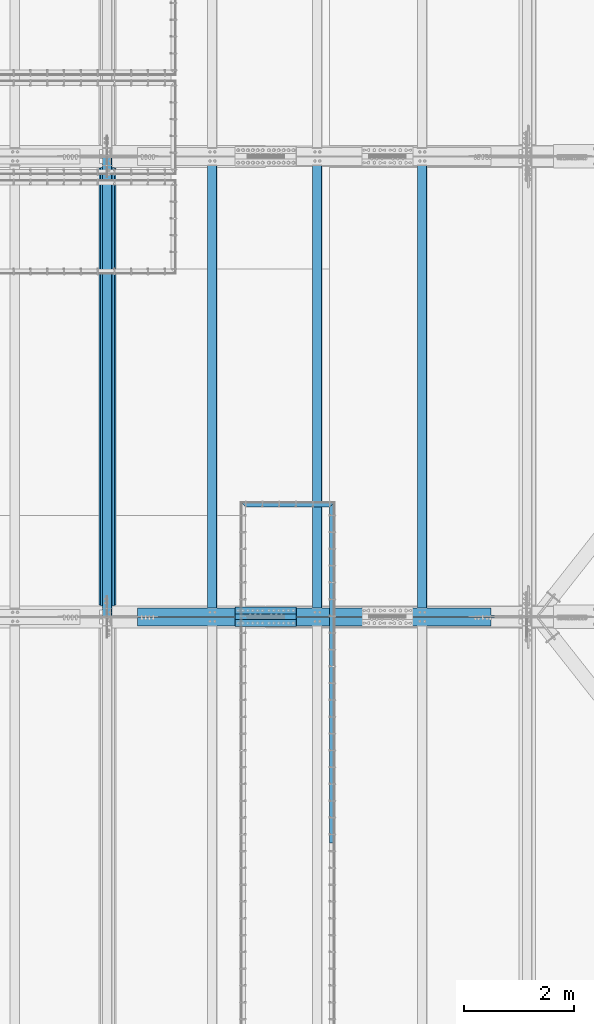
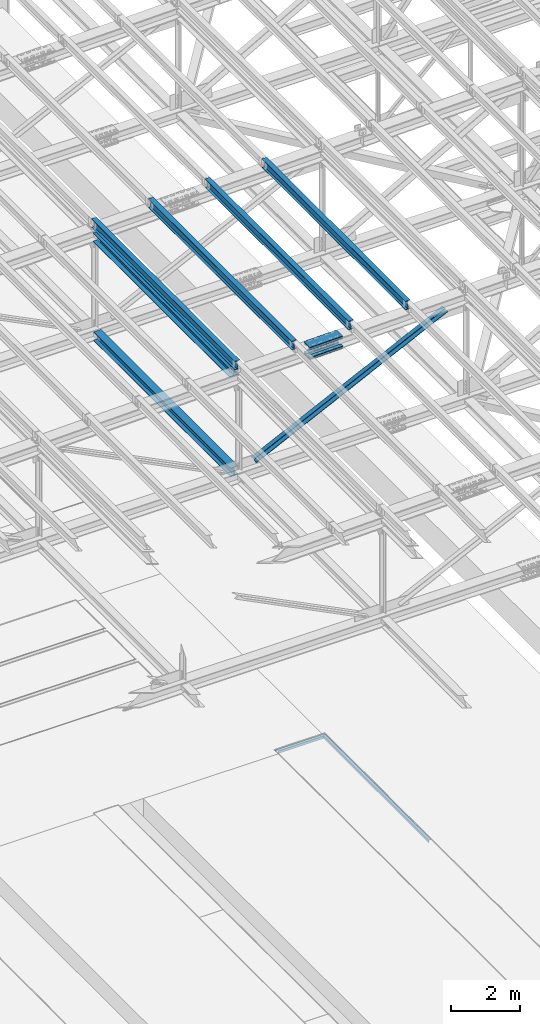
# One storey, part 1853 of 3843: 14 beams, 2 members, 11 elements without a shape of their own.
"""IFC2X3 building model written with IfcOpenShell, lengths in millimetres."""

from ifc_helpers import new_model, si_unit, frame, origin_with_axes, place, context, subcontext, project, spatial, faceted_brep, material, type_object, element, aggregate, save


model = new_model("IFC2X3")

# Units and contexts
model_context = context("Model", 3, precision=1e-05, world=origin_with_axes())
body_context = subcontext(model_context, "Body", "Model", "MODEL_VIEW")
ifc_project = project(units=[si_unit("LENGTHUNIT", "METRE", prefix="MILLI"), si_unit("AREAUNIT", "SQUARE_METRE"), si_unit("VOLUMEUNIT", "CUBIC_METRE"), si_unit("MASSUNIT", "GRAM", prefix="KILO"), si_unit("TIMEUNIT", "SECOND"), si_unit("PLANEANGLEUNIT", "RADIAN"), si_unit("SOLIDANGLEUNIT", "STERADIAN"), si_unit("THERMODYNAMICTEMPERATUREUNIT", "DEGREE_CELSIUS"), si_unit("LUMINOUSINTENSITYUNIT", "LUMEN")], contexts=[model_context])

# Site, building, storey
site_placement = place(None, origin_with_axes())
site = spatial("IfcSite", under=ifc_project, at=site_placement, CompositionType="ELEMENT")
building_placement = place(site_placement, origin_with_axes())
building = spatial("IfcBuilding", under=site, at=building_placement, Name="Undefined", CompositionType="ELEMENT")
storey_placement = place(building_placement, origin_with_axes())
storey = spatial("IfcBuildingStorey", under=building, at=storey_placement, Name="Undefined", CompositionType="ELEMENT", Elevation=0.0)

# Assembly, beam
assembly_1_placement = place(storey_placement, origin_with_axes())
assembly_1 = element("IfcElementAssembly", 1, at=assembly_1_placement, inside=storey, Name="EMBED_ANGLE", AssemblyPlace="NOTDEFINED", PredefinedType="RIGID_FRAME")
ifc_material_1 = material(Name="STEEL/A36")
beam_type_1 = type_object("IfcBeamType", Name="L3-1/2X3-1/2X5/16", PredefinedType="NOTDEFINED")
beam_1_placement = place(assembly_1_placement, frame((65056.5755709549, 52597.0501953125, 30410.15), z_axis=(0.0, 0.0, -1.0), x_axis=(1.0, 0.0, 0.0)))
beam_1 = element("IfcBeam", 2, at=beam_1_placement, type_object=beam_type_1, material=ifc_material_1, Name="EMBED_ANGLE", ObjectType="L3-1/2X3-1/2X5/16", context=body_context, shape_type="Brep", body=[
    faceted_brep([(88.8999999971129, 44.4500000000007, -44.4499999999971), (88.8999999965163, 44.4499999999971, 44.4500000000007), (1612.83647438452, 44.4499999999971, 44.4500000000007), (1612.83647438452, 44.4499999999971, -44.4500000000007), (80.9624999965163, 36.5124999999971, 44.4500000000007), (1620.7739717074, 36.5124999999971, 44.4500000000007), (80.9624999971129, 36.5125000000007, -36.5124999999971), (1620.77392277028, 36.5125000000007, -36.5125000083208), (3.63797880709171e-12, -44.4499999999971, -36.5125000000007), (1701.73644440077, -44.4500000000044, -36.5125000000007), (3.63797880709171e-12, -44.4499999999971, -44.4500000000007), (1701.73644440077, -44.4500000000044, -44.4500000000007)], [[[0, 1, 2, 3]], [[1, 4, 5, 2]], [[4, 6, 7, 5]], [[6, 8, 9, 7]], [[8, 10, 11, 9]], [[10, 0, 3, 11]], [[5, 7, 9, 11, 3, 2]], [[10, 8, 6, 4, 1, 0]]]),
])
aggregate(assembly_1, [beam_1])

assembly_2_placement = place(storey_placement, origin_with_axes())
assembly_2 = element("IfcElementAssembly", 3, at=assembly_2_placement, inside=storey, Name="EMBED_ANGLE", AssemblyPlace="NOTDEFINED", PredefinedType="RIGID_FRAME")
beam_2_placement = place(assembly_2_placement, frame((66713.8620305814, 52641.4996249862, 30410.15), z_axis=(0.0, 0.0, -1.0), x_axis=(0.0, -1.0, 0.0)))
beam_2 = element("IfcBeam", 4, at=beam_2_placement, type_object=beam_type_1, material=ifc_material_1, Name="EMBED_ANGLE", ObjectType="L3-1/2X3-1/2X5/16", context=body_context, shape_type="Brep", body=[
    faceted_brep([(88.8999999971129, 44.4500000000007, -44.4499999999971), (88.8999999965163, 44.4499999999971, 44.4500000000007), (6184.89942989353, 44.4500000362459, 44.4500000000007), (6184.89942989353, 44.4500000362459, -44.4500000000007), (80.9624999965163, 36.5124999999971, 44.4500000000007), (6184.89942989351, 36.5125000362459, 44.4500000000007), (80.9624999971129, 36.5125000000007, -36.5124999999971), (6184.89942989351, 36.5125000362459, -36.5125000000007), (3.63797880709171e-12, -44.4499999999971, -36.5125000000007), (6184.8994298934, -44.4499999637628, -36.5125000000007), (3.63797880709171e-12, -44.4499999999971, -44.4500000000007), (6184.8994298934, -44.4499999637628, -44.4500000000007)], [[[0, 1, 2, 3]], [[1, 4, 5, 2]], [[4, 6, 7, 5]], [[6, 8, 9, 7]], [[8, 10, 11, 9]], [[10, 0, 3, 11]], [[5, 7, 9, 11, 3, 2]], [[10, 8, 6, 4, 1, 0]]]),
])
aggregate(assembly_2, [beam_2])

assembly_3_placement = place(storey_placement, origin_with_axes())
assembly_3 = element("IfcElementAssembly", 5, at=assembly_3_placement, inside=storey, Name="BEAM", AssemblyPlace="NOTDEFINED", PredefinedType="RIGID_FRAME")
ifc_material_2 = material(Name="STEEL/A992")
beam_type_2 = type_object("IfcBeamType", Name="W12X26", PredefinedType="NOTDEFINED")
beam_3_placement = place(assembly_3_placement, frame((62633.1092623187, 50558.6422025775, 46219.7893078757), z_axis=(-0.0211520984675226, -0.000371508000112954, 0.999776200312963), x_axis=(0.0, 0.99999993095969, 0.000371591999985175)))
beam_3 = element("IfcBeam", 6, at=beam_3_placement, type_object=beam_type_2, material=ifc_material_2, Name="BEAM", ObjectType="W12X26", context=body_context, shape_type="Brep", body=[
    faceted_brep([(12.6993519677417, 82.5499999996464, -155.575000000448), (12.7028905899642, 82.5499999996537, -146.050000000418), (8343.90346575781, 82.5499999991371, -146.049999975963), (8343.89992713558, 82.5499999991225, -155.574999975994), (12.703514473782, 3.17499999978463, -146.050000000469), (8343.90408964162, 3.17499999926804, -146.049999976014), (12.8120322219984, 3.17500000020664, 146.050000000563), (8344.01260738984, 3.17499999969004, 146.05000002501), (12.8114083381806, 82.5500000000684, 146.050000000607), (8344.01198350602, 82.5499999995518, 146.050000025069), (12.8149469604105, 82.5500000000829, 155.575000000645), (8344.01552212825, 82.5499999995664, 155.575000025099), (12.8162446387505, -82.5499999996464, 155.575000000543), (8344.01681980658, -82.550000000163, 155.575000024997), (12.812706016528, -82.5499999996609, 146.050000000512), (8344.01328118436, -82.5500000001775, 146.050000024967), (12.8120821327102, -3.17499999979191, 146.050000000549), (8344.01265730055, -3.1750000003085, 146.05000002501), (12.7035643844938, -3.17500000020664, -146.050000000469), (8343.90413955232, -3.17500000072323, -146.049999976014), (12.7041882683043, -82.5500000000684, -146.05000000052), (8343.90476343614, -82.550000000585, -146.049999976058), (12.7006496460817, -82.5500000000829, -155.57500000055), (8343.90122481393, -82.5500000005995, -155.574999976096)], [[[0, 1, 2, 3]], [[1, 4, 5, 2]], [[4, 6, 7, 5]], [[6, 8, 9, 7]], [[8, 10, 11, 9]], [[10, 12, 13, 11]], [[12, 14, 15, 13]], [[14, 16, 17, 15]], [[16, 18, 19, 17]], [[18, 20, 21, 19]], [[20, 22, 23, 21]], [[22, 0, 3, 23]], [[5, 7, 9, 11, 13, 15, 17, 19, 21, 23, 3, 2]], [[22, 20, 18, 16, 14, 12, 10, 8, 6, 4, 1, 0]]]),
])
aggregate(assembly_3, [beam_3])

assembly_4_placement = place(storey_placement, origin_with_axes())
assembly_4 = element("IfcElementAssembly", 7, at=assembly_4_placement, inside=storey, Name="BEAM", AssemblyPlace="NOTDEFINED", PredefinedType="RIGID_FRAME")
beam_4_placement = place(assembly_4_placement, frame((68348.1092623159, 50558.6295614975, 46344.0380601221), z_axis=(-0.0211520981762442, -0.000452761999920767, 0.999776166824012), x_axis=(0.0, 0.999999897457093, 0.000452864000207387)))
beam_4 = element("IfcBeam", 8, at=beam_4_placement, type_object=beam_type_2, material=ifc_material_2, Name="BEAM", ObjectType="W12X26", context=body_context, shape_type="Brep", body=[
    faceted_brep([(12.6991634509395, 82.5499999998428, -155.574999999844), (12.7035230675392, 82.5500000008324, -146.049999999836), (8343.90437742035, 82.5500000011525, -146.050000015217), (8343.9000648554, 82.5500000011816, -155.575000015211), (12.7042834026215, 3.17500000041036, -146.049999999988), (8343.90513775544, 3.17500000073051, -146.05000001537), (12.8365353946574, 3.17499999965366, 146.049999999952), (8344.03738974747, 3.17499999997381, 146.049999984571), (12.8357750595824, 82.5500000000757, 146.050000000105), (8344.0366294124, 82.5500000003958, 146.049999984723), (12.8400876245432, 82.5500000000611, 155.575000000114), (8344.04094197735, 82.5500000003813, 155.574999984725), (12.8416691215025, -82.5500000008469, 155.574999999786), (8344.04252347432, -82.5500000005268, 155.574999984397), (12.8373565565416, -82.5500000008033, 146.049999999785), (8344.03821090936, -82.5500000004831, 146.049999984403), (12.8365962214666, -3.17500000036671, 146.049999999945), (8344.03745057428, -3.17500000004657, 146.049999984563), (12.7043442294234, -3.17499999962456, -146.049999999996), (8343.90519858224, -3.17499999930442, -146.050000015377), (12.7051045645057, -82.5500000000466, -146.050000000156), (8343.90595891731, -82.5499999997264, -146.050000015537), (12.700839471705, -82.5500000010798, -155.574999999444), (8343.90164635235, -82.5499999997119, -155.575000015531)], [[[0, 1, 2, 3]], [[1, 4, 5, 2]], [[4, 6, 7, 5]], [[6, 8, 9, 7]], [[8, 10, 11, 9]], [[10, 12, 13, 11]], [[12, 14, 15, 13]], [[14, 16, 17, 15]], [[16, 18, 19, 17]], [[18, 20, 21, 19]], [[20, 22, 23, 21]], [[22, 0, 3, 23]], [[5, 7, 9, 11, 13, 15, 17, 19, 21, 23, 3, 2]], [[22, 20, 18, 16, 14, 12, 10, 8, 6, 4, 1, 0]]]),
])
aggregate(assembly_4, [beam_4])

assembly_5_placement = place(storey_placement, origin_with_axes())
assembly_5 = element("IfcElementAssembly", 9, at=assembly_5_placement, inside=storey, Name="BEAM", AssemblyPlace="NOTDEFINED", PredefinedType="RIGID_FRAME")
beam_5_placement = place(assembly_5_placement, frame((66443.1092623624, 50558.6337716893, 46303.2830395796), z_axis=(-0.0211520979246561, -0.000425699999883364, 0.999776178718465), x_axis=(0.0, 0.999999909349305, 0.000425795000149042)))
beam_5 = element("IfcBeam", 10, at=beam_5_placement, type_object=beam_type_2, material=ifc_material_2, Name="BEAM", ObjectType="W12X26", context=body_context, shape_type="Brep", body=[
    faceted_brep([(12.6992577420606, 82.5500000004831, -155.575000000186), (12.7033125324306, 82.5500000004686, -146.050000000192), (8343.90406775389, 82.5500000007451, -146.050000013172), (8343.90001296352, 82.5500000007596, -155.575000013159), (12.7040274201136, 3.17500000004657, -146.049999999908), (8343.90478264158, 3.17500000032305, -146.050000012889), (12.8283743247084, 3.17499999998836, 146.049999999836), (8344.02912954616, 3.17500000025029, 146.049999986863), (12.8276594370109, 82.5500000004104, 146.049999999566), (8344.02841465847, 82.5500000006869, 146.049999986586), (12.8317142273809, 82.5500000004249, 155.574999999546), (8344.03246944884, 82.5500000006869, 155.574999986587), (12.8332011937746, -82.5500000004977, 155.575000000128), (8344.03395641524, -82.5500000002212, 155.574999987155), (12.8291464034119, -82.5500000004831, 146.050000000141), (8344.02990162488, -82.5500000002066, 146.049999987161), (12.8284315157143, -3.17500000004657, 146.049999999857), (8344.02918673718, -3.17499999977008, 146.049999986884), (12.704084611134, -3.17499999998836, -146.049999999886), (8343.90483983259, -3.17499999972642, -146.050000012867), (12.7047994988243, -82.5500000004104, -146.049999999617), (8343.90555472028, -82.5500000001339, -146.050000012583), (12.7007447084616, -82.5500000004249, -155.574999999604), (8343.90149992992, -82.5500000001484, -155.575000012577)], [[[0, 1, 2, 3]], [[1, 4, 5, 2]], [[4, 6, 7, 5]], [[6, 8, 9, 7]], [[8, 10, 11, 9]], [[10, 12, 13, 11]], [[12, 14, 15, 13]], [[14, 16, 17, 15]], [[16, 18, 19, 17]], [[18, 20, 21, 19]], [[20, 22, 23, 21]], [[22, 0, 3, 23]], [[5, 7, 9, 11, 13, 15, 17, 19, 21, 23, 3, 2]], [[22, 20, 18, 16, 14, 12, 10, 8, 6, 4, 1, 0]]]),
])
aggregate(assembly_5, [beam_5])

assembly_6_placement = place(storey_placement, origin_with_axes())
assembly_6 = element("IfcElementAssembly", 11, at=assembly_6_placement, inside=storey, Name="BEAM", AssemblyPlace="NOTDEFINED", PredefinedType="RIGID_FRAME")
beam_6_placement = place(assembly_6_placement, frame((64538.1092623442, 50558.637985359, 46261.8962503558), z_axis=(-0.021152097688544, -0.000398615999954926, 0.999776189888847), x_axis=(0.0, 0.999999920517158, 0.000398704999807439)))
beam_6 = element("IfcBeam", 12, at=beam_6_placement, type_object=beam_type_2, material=ifc_material_2, Name="BEAM", ObjectType="W12X26", context=body_context, shape_type="Brep", body=[
    faceted_brep([(12.6993519677417, 82.5499999996464, -155.575000000448), (12.7031016321926, 82.5499999993262, -146.05000000009), (8343.90376382439, 82.5499999992171, -146.049999995099), (8343.89992713558, 82.5499999991225, -155.574999975994), (12.7037710372169, 3.17499999947904, -146.050000000352), (8343.90443322941, 3.1749999993699, -146.049999995354), (12.8202067210586, 3.17500000050495, 146.050000000396), (8344.02086891326, 3.17500000038854, 146.050000005387), (12.8195373160343, 82.5500000003449, 146.05000000065), (8344.02019950824, 82.5500000002285, 146.050000005642), (12.8233341318119, 82.550000000374, 155.575000000674), (8344.02399632402, 82.5500000002648, 155.575000005665), (12.8247264942547, -82.5499999993117, 155.575000000143), (8344.02538868646, -82.5499999994136, 155.575000005134), (12.8209296784771, -82.5499999993408, 146.050000000112), (8344.02159187067, -82.5499999994427, 146.050000005103), (12.82026027346, -3.17499999949359, 146.050000000374), (8344.02092246566, -3.17499999960273, 146.050000005373), (12.7038245896183, -3.17500000050495, -146.050000000374), (8343.90448678181, -3.17500000062137, -146.049999995383), (12.7044939946281, -82.5500000003594, -146.050000000629), (8343.90515618683, -82.5500000004613, -146.049999995637), (12.7006496460817, -82.5500000000829, -155.57500000055), (8343.90135937105, -82.5500000004904, -155.574999995653)], [[[0, 1, 2, 3]], [[1, 4, 5, 2]], [[4, 6, 7, 5]], [[6, 8, 9, 7]], [[8, 10, 11, 9]], [[10, 12, 13, 11]], [[12, 14, 15, 13]], [[14, 16, 17, 15]], [[16, 18, 19, 17]], [[18, 20, 21, 19]], [[20, 22, 23, 21]], [[22, 0, 3, 23]], [[5, 7, 9, 11, 13, 15, 17, 19, 21, 23, 3, 2]], [[22, 20, 18, 16, 14, 12, 10, 8, 6, 4, 1, 0]]]),
])
aggregate(assembly_6, [beam_6])

# Assembly, beams
assembly_7_placement = place(storey_placement, origin_with_axes())
assembly_7 = element("IfcElementAssembly", 13, at=assembly_7_placement, inside=storey, Name="BEAM", AssemblyPlace="NOTDEFINED", PredefinedType="RIGID_FRAME")
ifc_material_3 = material(Name="STEEL/A572-50")
beam_type_3 = type_object("IfcBeamType", PredefinedType="NOTDEFINED")
beam_7_placement = place(assembly_7_placement, frame((64955.3532574287, 50673.0, 46066.1585524104), z_axis=(0.0, -1.0, 0.0), x_axis=(0.999763484909041, 0.0, 0.0217479709980223)))
beam_7 = element("IfcBeam", 14, at=beam_7_placement, type_object=beam_type_3, material=ifc_material_3, Name="PLATE", context=body_context, shape_type="Brep", body=[
    faceted_brep([(-4.36557456851006e-11, 12.7000000000116, -63.5), (-4.36557456851006e-11, 12.7000000000116, 63.5), (1104.90000001677, 12.7000000017251, 63.5), (1104.90000001677, 12.7000000017251, -63.5), (1.45519152283669e-11, -12.700000000008, 63.5), (1104.90000001682, -12.6999999982909, 63.5), (1.45519152283669e-11, -12.700000000008, -63.5), (1104.90000001682, -12.6999999982909, -63.5)], [[[0, 1, 2, 3]], [[1, 4, 5, 2]], [[4, 6, 7, 5]], [[6, 0, 3, 7]], [[5, 7, 3, 2]], [[6, 4, 1, 0]]]),
])
beam_8_placement = place(assembly_7_placement, frame((64961.7741729287, 50673.0, 45770.9863303139), z_axis=(0.0, -1.0, 0.0), x_axis=(0.999763484909041, 0.0, 0.0217479709980223)))
beam_8 = element("IfcBeam", 15, at=beam_8_placement, type_object=beam_type_3, material=ifc_material_3, Name="PLATE", context=body_context, shape_type="Brep", body=[
    faceted_brep([(-4.36557456851006e-11, 12.7000000000116, -63.5), (-4.36557456851006e-11, 12.7000000000116, 63.5), (1104.90000001677, 12.7000000017251, 63.5), (1104.90000001677, 12.7000000017251, -63.5), (1.45519152283669e-11, -12.700000000008, 63.5), (1104.90000001682, -12.6999999982909, 63.5), (1.45519152283669e-11, -12.700000000008, -63.5), (1104.90000001682, -12.6999999982909, -63.5)], [[[0, 1, 2, 3]], [[1, 4, 5, 2]], [[4, 6, 7, 5]], [[6, 0, 3, 7]], [[5, 7, 3, 2]], [[6, 4, 1, 0]]]),
])
beam_9_placement = place(assembly_7_placement, frame((64955.3532574287, 50444.4, 46066.1585524104), z_axis=(0.0, -1.0, 0.0), x_axis=(0.999763484909041, 0.0, 0.0217479709980223)))
beam_9 = element("IfcBeam", 16, at=beam_9_placement, type_object=beam_type_3, material=ifc_material_3, Name="PLATE", context=body_context, shape_type="Brep", body=[
    faceted_brep([(-4.36557456851006e-11, 12.7000000000116, -63.5), (-4.36557456851006e-11, 12.7000000000116, 63.5), (1104.90000001677, 12.7000000017251, 63.5), (1104.90000001677, 12.7000000017251, -63.5), (1.45519152283669e-11, -12.700000000008, 63.5), (1104.90000001682, -12.6999999982909, 63.5), (1.45519152283669e-11, -12.700000000008, -63.5), (1104.90000001682, -12.6999999982909, -63.5)], [[[0, 1, 2, 3]], [[1, 4, 5, 2]], [[4, 6, 7, 5]], [[6, 0, 3, 7]], [[5, 7, 3, 2]], [[6, 4, 1, 0]]]),
])
beam_10_placement = place(assembly_7_placement, frame((64961.7741729287, 50444.4, 45770.9863303139), z_axis=(0.0, -1.0, 0.0), x_axis=(0.999763484909041, 0.0, 0.0217479709980223)))
beam_10 = element("IfcBeam", 17, at=beam_10_placement, type_object=beam_type_3, material=ifc_material_3, Name="PLATE", context=body_context, shape_type="Brep", body=[
    faceted_brep([(-4.36557456851006e-11, 12.7000000000116, -63.5), (-4.36557456851006e-11, 12.7000000000116, 63.5), (1104.90000001677, 12.7000000017251, 63.5), (1104.90000001677, 12.7000000017251, -63.5), (1.45519152283669e-11, -12.700000000008, 63.5), (1104.90000001682, -12.6999999982909, 63.5), (1.45519152283669e-11, -12.700000000008, -63.5), (1104.90000001682, -12.6999999982909, -63.5)], [[[0, 1, 2, 3]], [[1, 4, 5, 2]], [[4, 6, 7, 5]], [[6, 0, 3, 7]], [[5, 7, 3, 2]], [[6, 4, 1, 0]]]),
])
beam_type_4 = type_object("IfcBeamType", PredefinedType="NOTDEFINED")
beam_11_placement = place(assembly_7_placement, frame((66058.6431732579, 50558.7, 46152.1908950063), z_axis=(0.0, -1.0, 0.0), x_axis=(-0.99976348490904, 0.0, -0.0217479709980245)))
beam_11 = element("IfcBeam", 18, at=beam_11_placement, type_object=beam_type_4, material=ifc_material_3, Name="PLATE", context=body_context, shape_type="Brep", body=[
    faceted_brep([(-1.45519152283669e-11, 12.7000000000025, -177.800000000003), (-1.45519152283669e-11, 12.7000000000025, 177.800000000003), (1104.90000001682, 12.7000000017051, 177.800000000003), (1104.90000001682, 12.7000000017051, -177.800000000003), (4.36557456851006e-11, -12.7000000000171, 177.800000000003), (1104.90000001686, -12.6999999983072, 177.800000000003), (4.36557456851006e-11, -12.7000000000171, -177.800000000003), (1104.90000001686, -12.6999999983072, -177.800000000003)], [[[0, 1, 2, 3]], [[1, 4, 5, 2]], [[4, 6, 7, 5]], [[6, 0, 3, 7]], [[5, 7, 3, 2]], [[6, 4, 1, 0]]]),
])
beam_12_placement = place(assembly_7_placement, frame((66067.7672737465, 50558.7, 45733.0850216141), z_axis=(0.0, -1.0, 0.0), x_axis=(-0.99976348490904, 0.0, -0.0217479709980245)))
beam_12 = element("IfcBeam", 19, at=beam_12_placement, type_object=beam_type_4, material=ifc_material_3, Name="PLATE", context=body_context, shape_type="Brep", body=[
    faceted_brep([(-1.45519152283669e-11, 12.7000000000025, -177.800000000003), (-1.45519152283669e-11, 12.7000000000025, 177.800000000003), (1104.90000001682, 12.7000000017051, 177.800000000003), (1104.90000001682, 12.7000000017051, -177.800000000003), (4.36557456851006e-11, -12.7000000000171, 177.800000000003), (1104.90000001686, -12.6999999983072, 177.800000000003), (4.36557456851006e-11, -12.7000000000171, -177.800000000003), (1104.90000001686, -12.6999999983072, -177.800000000003)], [[[0, 1, 2, 3]], [[1, 4, 5, 2]], [[4, 6, 7, 5]], [[6, 0, 3, 7]], [[5, 7, 3, 2]], [[6, 4, 1, 0]]]),
])
aggregate(assembly_7, [beam_7, beam_8, beam_9, beam_10, beam_11, beam_12])

# Assembly, member
assembly_8_placement = place(storey_placement, origin_with_axes())
assembly_8 = element("IfcElementAssembly", 20, at=assembly_8_placement, inside=storey, Name="ANGLE", AssemblyPlace="NOTDEFINED", PredefinedType="RIGID_FRAME")
member_type = type_object("IfcMemberType", Name="L6X6X1/2", PredefinedType="NOTDEFINED")
member_1_placement = place(assembly_8_placement, frame((70256.3999989677, 50644.425, 46031.6711838846), z_axis=(0.0, 1.0, 0.0), x_axis=(-0.899992800070875, 0.0, -0.435904760034328)))
member_1 = element("IfcMember", 21, at=member_1_placement, type_object=member_type, material=ifc_material_3, Name="ANGLE", ObjectType="L6X6X1/2", context=body_context, shape_type="Brep", body=[
    faceted_brep([(699.69878303376, 76.1999999977379, -76.1999999999971), (699.69878303376, 76.1999999977379, 76.1999999999971), (7828.92530205083, 76.1999999764703, 76.1999999999971), (7828.92530205083, 76.1999999764703, -76.1999999999971), (699.698783033833, 63.4999999977626, 76.1999999999971), (7828.92530205092, 63.499999976495, 76.1999999999971), (699.698783033833, 63.4999999977626, -63.5), (7828.92530205092, 63.499999976495, -63.5), (699.69878303475, -76.2000000019034, -63.5), (7828.92530205184, -76.2000000231747, -63.5), (699.69878303475, -76.2000000019034, -76.1999999999971), (7828.92530205184, -76.2000000231747, -76.1999999999971)], [[[0, 1, 2, 3]], [[1, 4, 5, 2]], [[4, 6, 7, 5]], [[6, 8, 9, 7]], [[8, 10, 11, 9]], [[10, 0, 3, 11]], [[5, 7, 9, 11, 3, 2]], [[10, 8, 6, 4, 1, 0]]]),
])
aggregate(assembly_8, [member_1])

assembly_9_placement = place(storey_placement, origin_with_axes())
assembly_9 = element("IfcElementAssembly", 22, at=assembly_9_placement, inside=storey, Name="ANGLE", AssemblyPlace="NOTDEFINED", PredefinedType="RIGID_FRAME")
member_2_placement = place(assembly_9_placement, frame((62636.4000016938, 50472.975, 42340.9813633578), z_axis=(0.0, -1.0, 0.0), x_axis=(0.899992800070875, 0.0, 0.43590476003433)))
member_2 = element("IfcMember", 23, at=member_2_placement, type_object=member_type, material=ifc_material_3, Name="ANGLE", ObjectType="L6X6X1/2", context=body_context, shape_type="Brep", body=[
    faceted_brep([(637.809092627242, 76.2000000019707, -76.1999999999971), (637.809092627242, 76.2000000019707, 76.1999999999971), (7767.03561164431, 76.2000000232347, 76.1999999999971), (7767.03561164431, 76.2000000232347, -76.1999999999971), (637.809092627227, 63.5000000019591, 76.1999999999971), (7767.03561164431, 63.500000023223, 76.1999999999971), (637.809092627227, 63.5000000019591, -63.5), (7767.03561164431, 63.500000023223, -63.5), (637.809092627227, -76.1999999981581, -63.5), (7767.03561164431, -76.1999999768905, -63.5), (637.809092627227, -76.1999999981581, -76.1999999999971), (7767.03561164431, -76.1999999768905, -76.1999999999971)], [[[0, 1, 2, 3]], [[1, 4, 5, 2]], [[4, 6, 7, 5]], [[6, 8, 9, 7]], [[8, 10, 11, 9]], [[10, 0, 3, 11]], [[5, 7, 9, 11, 3, 2]], [[10, 8, 6, 4, 1, 0]]]),
])
aggregate(assembly_9, [member_2])

# Assembly, beam
assembly_10_placement = place(storey_placement, origin_with_axes())
assembly_10 = element("IfcElementAssembly", 24, at=assembly_10_placement, inside=storey, Name="BEAM", AssemblyPlace="NOTDEFINED", PredefinedType="RIGID_FRAME")
beam_type_5 = type_object("IfcBeamType", Name="W12X65", PredefinedType="NOTDEFINED")
beam_13_placement = place(assembly_10_placement, frame((62636.4, 50558.7000000007, 45867.3493196731), z_axis=(0.0, -0.000371591999988596, 0.99999993095969), x_axis=(0.0, 0.99999993095969, 0.000371591999985175)))
beam_13 = element("IfcBeam", 25, at=beam_13_placement, type_object=beam_type_5, material=ifc_material_2, Name="BEAM", ObjectType="W12X65", context=body_context, shape_type="Brep", body=[
    faceted_brep([(212.66779415834, 152.400000000001, -153.987499999181), (212.67369318175, 152.400000000001, -138.112499999195), (8143.82424073101, 152.400000000001, -138.112499975905), (8143.8183417076, 152.400000000001, -153.98749997589), (212.67369318175, 4.76249999999709, -138.112499999195), (8143.82424073101, 4.76249999999709, -138.112499975905), (212.776336189032, 4.76249999999709, 138.112500000454), (8143.92688373829, 4.76249999999709, 138.112500023744), (212.776336189032, 152.400000000001, 138.112500000454), (8143.92688373829, 152.400000000001, 138.112500023744), (212.782235212442, 152.400000000001, 153.987500000439), (8143.9327827617, 152.400000000001, 153.98750002373), (212.782235212442, -152.400000000001, 153.987500000439), (8143.9327827617, -152.400000000001, 153.98750002373), (212.776336189032, -152.400000000001, 138.112500000454), (8143.92688373829, -152.400000000001, 138.112500023744), (212.776336189032, -4.76249999999709, 138.112500000454), (8143.92688373829, -4.76249999999709, 138.112500023744), (212.67369318175, -4.76249999999709, -138.112499999195), (8143.82424073101, -4.76249999999709, -138.112499975905), (212.67369318175, -152.400000000001, -138.112499999195), (8143.82424073101, -152.400000000001, -138.112499975905), (212.66779415834, -152.400000000001, -153.987499999181), (8143.8183417076, -152.400000000001, -153.98749997589)], [[[0, 1, 2, 3]], [[1, 4, 5, 2]], [[4, 6, 7, 5]], [[6, 8, 9, 7]], [[8, 10, 11, 9]], [[10, 12, 13, 11]], [[12, 14, 15, 13]], [[14, 16, 17, 15]], [[16, 18, 19, 17]], [[18, 20, 21, 19]], [[20, 22, 23, 21]], [[22, 0, 3, 23]], [[5, 7, 9, 11, 13, 15, 17, 19, 21, 23, 3, 2]], [[22, 20, 18, 16, 14, 12, 10, 8, 6, 4, 1, 0]]]),
])
aggregate(assembly_10, [beam_13])

assembly_11_placement = place(storey_placement, origin_with_axes())
assembly_11 = element("IfcElementAssembly", 26, at=assembly_11_placement, inside=storey, Name="BEAM", AssemblyPlace="NOTDEFINED", PredefinedType="RIGID_FRAME")
beam_type_6 = type_object("IfcBeamType", Name="W12X53", PredefinedType="NOTDEFINED")
beam_14_placement = place(assembly_11_placement, frame((62636.4, 50558.7, 42341.011619196), z_axis=(0.0, -0.000369886999847949, 0.999999931591801), x_axis=(0.0, 0.999999931591801, 0.000369886999848637)))
beam_14 = element("IfcBeam", 27, at=beam_14_placement, type_object=beam_type_6, material=ifc_material_2, Name="BEAM", ObjectType="W12X53", context=body_context, shape_type="Brep", body=[
    faceted_brep([(198.381142792023, 127.0, -152.400000000176), (198.386427552898, 127.0, -138.112500000185), (8158.11197205773, 127.0, -138.112500009564), (8158.10668729685, 127.0, -152.400000009562), (198.386427552898, 4.76249999999709, -138.112500000185), (8158.11197205773, 4.76249999999709, -138.112500009564), (198.488599596414, 4.76249999999709, 138.112499999719), (8158.21414410125, 4.76249999999709, 138.112499990333), (198.488599596414, 127.0, 138.112499999719), (8158.21414410125, 127.0, 138.112499990333), (198.493884357289, 127.0, 152.399999999718), (8158.21942886212, 127.0, 152.399999990324), (198.493884357289, -127.0, 152.399999999718), (8158.21942886212, -127.0, 152.399999990324), (198.488599596414, -127.0, 138.112499999719), (8158.21414410125, -127.0, 138.112499990333), (198.488599596414, -4.76249999999709, 138.112499999719), (8158.21414410125, -4.76249999999709, 138.112499990333), (198.386427552898, -4.76249999999709, -138.112500000185), (8158.11197205773, -4.76249999999709, -138.112500009564), (198.386427552898, -127.0, -138.112500000185), (8158.11197205773, -127.0, -138.112500009564), (198.381142792023, -127.0, -152.400000000176), (8158.10668729685, -127.0, -152.400000009562)], [[[0, 1, 2, 3]], [[1, 4, 5, 2]], [[4, 6, 7, 5]], [[6, 8, 9, 7]], [[8, 10, 11, 9]], [[10, 12, 13, 11]], [[12, 14, 15, 13]], [[14, 16, 17, 15]], [[16, 18, 19, 17]], [[18, 20, 21, 19]], [[20, 22, 23, 21]], [[22, 0, 3, 23]], [[5, 7, 9, 11, 13, 15, 17, 19, 21, 23, 3, 2]], [[22, 20, 18, 16, 14, 12, 10, 8, 6, 4, 1, 0]]]),
])
aggregate(assembly_11, [beam_14])

save(model, "model.ifc")
